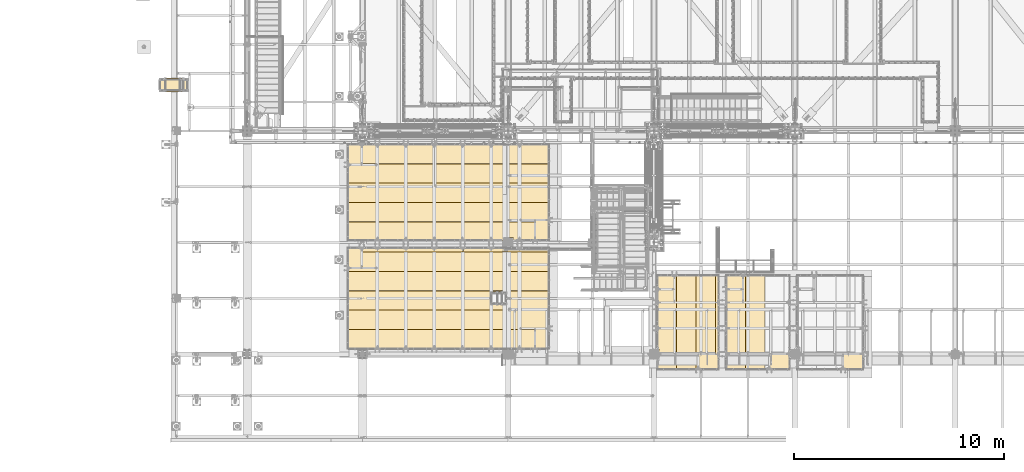
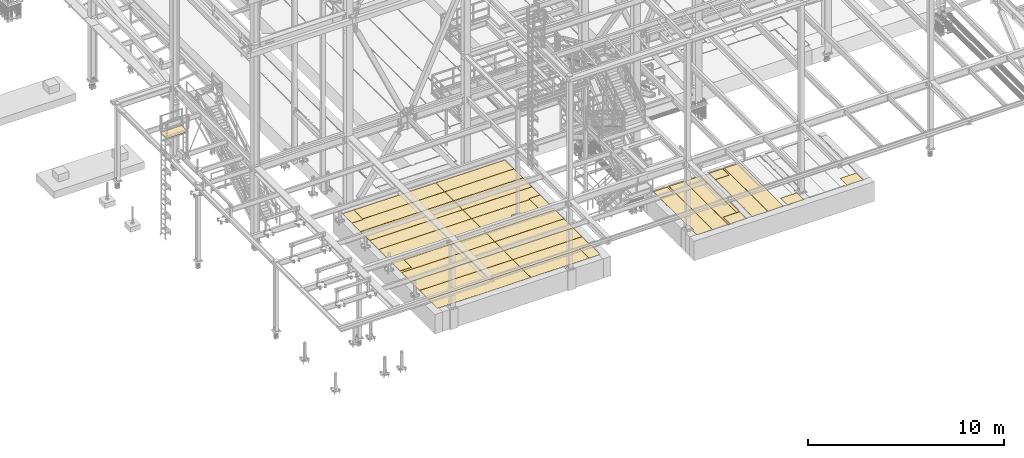
# One storey, part 3837 of 3843: 38 coverings.
"""IFC2X3 building model written with IfcOpenShell, lengths in millimetres."""

from ifc_helpers import new_model, si_unit, frame, origin_with_axes, place, context, subcontext, project, spatial, faceted_brep, material, element, save


model = new_model("IFC2X3")

# Units and contexts
model_context = context("Model", 3, precision=1e-05, world=origin_with_axes())
body_context = subcontext(model_context, "Body", "Model", "MODEL_VIEW")
ifc_project = project(units=[si_unit("LENGTHUNIT", "METRE", prefix="MILLI"), si_unit("AREAUNIT", "SQUARE_METRE"), si_unit("VOLUMEUNIT", "CUBIC_METRE"), si_unit("MASSUNIT", "GRAM", prefix="KILO"), si_unit("TIMEUNIT", "SECOND"), si_unit("PLANEANGLEUNIT", "RADIAN"), si_unit("SOLIDANGLEUNIT", "STERADIAN"), si_unit("THERMODYNAMICTEMPERATUREUNIT", "DEGREE_CELSIUS"), si_unit("LUMINOUSINTENSITYUNIT", "LUMEN")], contexts=[model_context])

# Site, building, storey
site_placement = place(None, origin_with_axes())
site = spatial("IfcSite", under=ifc_project, at=site_placement, CompositionType="ELEMENT")
building_placement = place(site_placement, origin_with_axes())
building = spatial("IfcBuilding", under=site, at=building_placement, Name="Undefined", CompositionType="ELEMENT")
storey_placement = place(building_placement, origin_with_axes())
storey = spatial("IfcBuildingStorey", under=building, at=storey_placement, Name="Undefined", CompositionType="ELEMENT", Elevation=0.0)

# Coverings
ifc_material = material(Name="Undefined/1")
covering_1_placement = place(storey_placement, frame((32457.5233459467, 27476.4499999546, 36765.0760559082), z_axis=(0.0, 1.0, 0.0), x_axis=(1.0, 0.0, 0.0)))
element("IfcCovering", 1, at=covering_1_placement, inside=storey, material=ifc_material, Name="SurfaceTreatment", PredefinedType="NOTDEFINED", context=body_context, shape_type="Brep", body=[
    faceted_brep([(2.88564478978515e-08, -0.5, 647.700000045399), (1247.1656799484, -0.5, 647.699999991924), (1247.1656799484, 0.5, 647.699999991924), (2.88564478978515e-08, 0.5, 647.700000045399), (1247.1656799196, -0.5, -9.38598532229662e-10), (1247.1656799196, 0.5, -9.38598532229662e-10), (0.0, -0.5, 0.0), (0.0, 0.5, 0.0)], [[[0, 1, 2, 3]], [[1, 4, 5, 2]], [[4, 6, 7, 5]], [[6, 0, 3, 7]], [[5, 7, 3, 2]], [[6, 4, 1, 0]]]),
])
for number, where, z_axis, x_axis, name in (
    (2, (59359.7998124687, 18084.8000089393, 30479.2065), (0.0, 1.0, 0.0), (1.0, 0.0, 0.0), "SurfaceTreatment"),
    (3, (56089.5498483771, 18084.8000089393, 30479.2065), (0.0, 1.0, 0.0), (1.0, 0.0, 0.0), "SurfaceTreatment"),
):
    element("IfcCovering", number, at=place(storey_placement, frame(where, z_axis=z_axis, x_axis=x_axis)), inside=storey, material=ifc_material, Name=name, PredefinedType="NOTDEFINED", context=body_context, shape_type="Brep", body=[
        faceted_brep([(-1.84064265340567e-06, -0.793499999999767, 657.224795748214), (809.625124790451, -0.793499999999767, 657.224750979309), (809.625124790451, 0.793499999999767, 657.224750979309), (-1.84064265340567e-06, 0.793499999999767, 657.224795748214), (809.625131159271, -0.793499999999767, -1.3606040738523e-09), (809.625131159271, 0.793499999999767, -1.3606040738523e-09), (-1.45519152283669e-11, -0.793499999999767, 0.0), (-1.45519152283669e-11, 0.793499999999767, 0.0)], [[[0, 1, 2, 3]], [[1, 4, 5, 2]], [[4, 6, 7, 5]], [[6, 0, 3, 7]], [[5, 7, 3, 2]], [[6, 4, 1, 0]]]),
    ])
covering_2_placement = place(storey_placement, frame((41367.075, 20412.0736968403, 30479.2065), z_axis=(0.0, 1.0, 0.0), x_axis=(1.0, 0.0, 0.0)))
element("IfcCovering", 4, at=covering_2_placement, inside=storey, material=ifc_material, Name="SurfaceTreatment", PredefinedType="NOTDEFINED", context=body_context, shape_type="Brep", body=[
    faceted_brep([(0.0, -0.793499999999767, 879.476196497068), (5486.39990234375, -0.793499999999767, 879.476196497068), (5486.39990234375, 0.793499999999767, 879.476196497068), (0.0, 0.793499999999767, 879.476196497068), (5486.39990234375, -0.793499999999767, 0.0), (5486.39990234375, 0.793499999999767, 0.0), (-1.45519152283669e-11, -0.793499999999767, 0.0), (-1.45519152283669e-11, 0.793499999999767, 0.0)], [[[0, 1, 2, 3]], [[1, 4, 5, 2]], [[4, 6, 7, 5]], [[6, 0, 3, 7]], [[5, 7, 3, 2]], [[6, 4, 1, 0]]]),
])
for number, where, z_axis, x_axis, name in (
    (5, (58042.1750028718, 14277.9750716518, 30479.2065), (0.0, 1.0, 0.0), (1.0, 0.0, 0.0), "SurfaceTreatment"),
    (6, (61420.3749756004, 14277.9750719499, 30479.2065), (0.0, 1.0, 0.0), (1.0, 0.0, 0.0), "SurfaceTreatment"),
    (7, (64931.9249999974, 14277.9751077968, 30479.2065), (0.0, 1.0, 0.0), (1.0, 0.0, 0.0), "SurfaceTreatment"),
):
    element("IfcCovering", number, at=place(storey_placement, frame(where, z_axis=z_axis, x_axis=x_axis)), inside=storey, material=ifc_material, Name=name, PredefinedType="NOTDEFINED", context=body_context, shape_type="Brep", body=[
        faceted_brep([(3.82465441362001e-05, -0.793499999999767, 717.549920835538), (962.025013836021, -0.793499999999767, 717.549869919043), (962.025013836021, 0.793499999999767, 717.549869919043), (3.82465441362001e-05, 0.793499999999767, 717.549920835538), (962.025033763661, -0.793499999999767, -2.58842192124575e-09), (962.025033763661, 0.793499999999767, -2.58842192124575e-09), (-1.45519152283669e-11, -0.793499999999767, 0.0), (-1.45519152283669e-11, 0.793499999999767, 0.0)], [[[0, 1, 2, 3]], [[1, 4, 5, 2]], [[4, 6, 7, 5]], [[6, 0, 3, 7]], [[5, 7, 3, 2]], [[6, 4, 1, 0]]]),
    ])
for number, where, z_axis, x_axis, name in (
    (8, (42024.2999786377, 24012.525, 30479.2065), (-1.0, 0.0, 0.0), (0.0, 1.0, 0.0), "SurfaceTreatment"),
    (9, (50936.525066285, 20412.0737027925, 30479.2065), (-1.0, 0.0, 0.0), (0.0, 1.0, 0.0), "SurfaceTreatment"),
    (10, (42024.2999771804, 19094.4499999116, 30479.2065), (-1.0, 0.0, 0.0), (0.0, 1.0, 0.0), "SurfaceTreatment"),
    (11, (50936.5249755859, 15252.6999815394, 30479.2065), (-1.0, 0.0, 0.0), (0.0, 1.0, 0.0), "SurfaceTreatment"),
):
    element("IfcCovering", number, at=place(storey_placement, frame(where, z_axis=z_axis, x_axis=x_axis)), inside=storey, material=ifc_material, Name=name, PredefinedType="NOTDEFINED", context=body_context, shape_type="Brep", body=[
        faceted_brep([(0.0, -0.793499999999767, 657.224975585938), (962.025048828131, -0.793499999999767, 657.224975585938), (962.025048828131, 0.793499999999767, 657.224975585938), (0.0, 0.793499999999767, 657.224975585938), (962.025033763661, -0.793499999999767, -2.58842192124575e-09), (962.025033763661, 0.793499999999767, -2.58842192124575e-09), (-1.45519152283669e-11, -0.793499999999767, 0.0), (-1.45519152283669e-11, 0.793499999999767, 0.0)], [[[0, 1, 2, 3]], [[1, 4, 5, 2]], [[4, 6, 7, 5]], [[6, 0, 3, 7]], [[5, 7, 3, 2]], [[6, 4, 1, 0]]]),
    ])
covering_3_placement = place(storey_placement, frame((61194.9500488281, 14277.9750708574, 30479.2065), z_axis=(-1.0, 0.0, 0.0), x_axis=(0.0, 1.0, 0.0)))
element("IfcCovering", 12, at=covering_3_placement, inside=storey, material=ifc_material, Name="SurfaceTreatment", PredefinedType="NOTDEFINED", context=body_context, shape_type="Brep", body=[
    faceted_brep([(5.36783772986382e-09, -0.793499999999767, 914.400024414062), (4464.04980469289, -0.793499999999767, 914.400025033865), (4464.04980469289, 0.793499999999767, 914.400025033865), (5.36783772986382e-09, 0.793499999999767, 914.400024414062), (4464.04980468753, -0.793499999999767, 1.42608769237995e-08), (4464.04980468753, 0.793499999999767, 1.42608769237995e-08), (-1.45519152283669e-11, -0.793499999999767, 0.0), (-1.45519152283669e-11, 0.793499999999767, 0.0)], [[[0, 1, 2, 3]], [[1, 4, 5, 2]], [[4, 6, 7, 5]], [[6, 0, 3, 7]], [[5, 7, 3, 2]], [[6, 4, 1, 0]]]),
])
covering_4_placement = place(storey_placement, frame((59359.7998474532, 18078.450000003, 30479.2065), z_axis=(1.0, 0.0, 0.0), x_axis=(0.0, -1.0, 0.0)))
element("IfcCovering", 13, at=covering_4_placement, inside=storey, material=ifc_material, Name="SurfaceTreatment", PredefinedType="NOTDEFINED", context=body_context, shape_type="Brep", body=[
    faceted_brep([(-663.574804554046, -0.793499999999767, 914.400025016796), (3800.47500013346, -0.793499999999767, 914.400024430266), (3800.47500013346, 0.793499999999767, 914.400024430266), (-663.574804554046, 0.793499999999767, 914.400025016796), (3800.47500000001, -0.793499999999767, 1.61962816491723e-08), (3800.47500000001, 0.793499999999767, 1.61962816491723e-08), (-1.45519152283669e-11, -0.793499999999767, 0.0), (-1.45519152283669e-11, 0.793499999999767, 0.0), (3.27607158396859e-05, -0.793499999999767, 815.97517946842), (3.27607158396859e-05, 0.793499999999767, 815.97517946842), (-663.574771926786, -0.793499999999767, 815.975206098316), (-663.574771926786, 0.793499999999767, 815.975206098316)], [[[0, 1, 2, 3]], [[1, 4, 5, 2]], [[4, 6, 7, 5]], [[6, 8, 9, 7]], [[8, 10, 11, 9]], [[10, 0, 3, 11]], [[5, 7, 9, 11, 3, 2]], [[10, 8, 6, 4, 1, 0]]]),
])
covering_5_placement = place(storey_placement, frame((59004.1996849625, 15001.8748353989, 30479.2065), z_axis=(-1.0, 0.0, 0.0), x_axis=(0.0, 1.0, 0.0)))
element("IfcCovering", 14, at=covering_5_placement, inside=storey, material=ifc_material, Name="SurfaceTreatment", PredefinedType="NOTDEFINED", context=body_context, shape_type="Brep", body=[
    faceted_brep([(-2.46302333835047e-05, -0.793499999999767, 152.399899291995), (3740.15012185445, -0.793499999999767, 152.399900893091), (3740.15012185445, 0.793499999999767, 152.399900893091), (-2.46302333835047e-05, 0.793499999999767, 152.399899291995), (3740.15014648466, -0.793499999999767, 9.69885149970651e-09), (3740.15014648466, 0.793499999999767, 9.69885149970651e-09), (-1.45519152283669e-11, -0.793499999999767, 0.0), (-1.45519152283669e-11, 0.793499999999767, 0.0)], [[[0, 1, 2, 3]], [[1, 4, 5, 2]], [[4, 6, 7, 5]], [[6, 0, 3, 7]], [[5, 7, 3, 2]], [[6, 4, 1, 0]]]),
])
covering_6_placement = place(storey_placement, frame((58845.4498946794, 18742.0249124911, 30479.2065000002), z_axis=(0.0, -1.0, 0.0), x_axis=(-1.0, 0.0, 0.0)))
element("IfcCovering", 15, at=covering_6_placement, inside=storey, material=ifc_material, Name="SurfaceTreatment", PredefinedType="NOTDEFINED", context=body_context, shape_type="Brep", body=[
    faceted_brep([(4.7221255954355e-05, -0.793499999999767, 3740.14984131871), (809.625020269006, -0.793499999999767, 3740.14996743444), (809.625020269006, 0.793499999999767, 3740.14996743444), (4.7221255954355e-05, 0.793499999999767, 3740.14984131871), (809.624897506437, -0.793499999999767, 4464.04980468742), (809.624897506437, 0.793499999999767, 4464.04980468742), (914.400024350987, -0.793499999999767, 4464.04980468712), (914.400024350987, 0.793499999999767, 4464.04980468712), (914.400025019604, -0.793499999999767, -3.92901711165905e-10), (914.400025019604, 0.793499999999767, -3.92901711165905e-10), (-1.45519152283669e-11, -0.793499999999767, 0.0), (-1.45519152283669e-11, 0.793499999999767, 0.0)], [[[0, 1, 2, 3]], [[1, 4, 5, 2]], [[4, 6, 7, 5]], [[6, 8, 9, 7]], [[8, 10, 11, 9]], [[10, 0, 3, 11]], [[5, 7, 9, 11, 3, 2]], [[10, 8, 6, 4, 1, 0]]]),
])
covering_7_placement = place(storey_placement, frame((57924.7000488281, 14277.9750708574, 30479.2065), z_axis=(-1.0, 0.0, 0.0), x_axis=(0.0, 1.0, 0.0)))
element("IfcCovering", 16, at=covering_7_placement, inside=storey, material=ifc_material, Name="SurfaceTreatment", PredefinedType="NOTDEFINED", context=body_context, shape_type="Brep", body=[
    faceted_brep([(5.36783772986382e-09, -0.793499999999767, 914.400024414062), (4464.04980469289, -0.793499999999767, 914.400025033865), (4464.04980469289, 0.793499999999767, 914.400025033865), (5.36783772986382e-09, 0.793499999999767, 914.400024414062), (4464.04980468753, -0.793499999999767, 1.42608769237995e-08), (4464.04980468753, 0.793499999999767, 1.42608769237995e-08), (-1.45519152283669e-11, -0.793499999999767, 0.0), (-1.45519152283669e-11, 0.793499999999767, 0.0)], [[[0, 1, 2, 3]], [[1, 4, 5, 2]], [[4, 6, 7, 5]], [[6, 0, 3, 7]], [[5, 7, 3, 2]], [[6, 4, 1, 0]]]),
])
covering_8_placement = place(storey_placement, frame((56089.5498474532, 18078.450000003, 30479.2065), z_axis=(1.0, 0.0, 0.0), x_axis=(0.0, -1.0, 0.0)))
element("IfcCovering", 17, at=covering_8_placement, inside=storey, material=ifc_material, Name="SurfaceTreatment", PredefinedType="NOTDEFINED", context=body_context, shape_type="Brep", body=[
    faceted_brep([(-663.574804554046, -0.793499999999767, 914.400025016796), (3800.47500013346, -0.793499999999767, 914.400024430266), (3800.47500013346, 0.793499999999767, 914.400024430266), (-663.574804554046, 0.793499999999767, 914.400025016796), (3800.47500000001, -0.793499999999767, 1.61962816491723e-08), (3800.47500000001, 0.793499999999767, 1.61962816491723e-08), (3321.04998346353, -0.793499999999767, 1.41662894748151e-08), (3321.04998346353, 0.793499999999767, 1.41662894748151e-08), (3321.05000331433, -0.793499999999767, 82.5500147743296), (3321.05000331433, 0.793499999999767, 82.5500147743296), (2838.45000331432, -0.793499999999767, 82.5500341415318), (2838.45000331432, 0.793499999999767, 82.5500341415318), (2838.44998346422, -0.793499999999767, 1.20926415547729e-08), (2838.44998346422, 0.793499999999767, 1.20926415547729e-08), (-1.45519152283669e-11, -0.793499999999767, 0.0), (-1.45519152283669e-11, 0.793499999999767, 0.0), (3.27607158396859e-05, -0.793499999999767, 815.97517946842), (3.27607158396859e-05, 0.793499999999767, 815.97517946842), (-663.574771926786, -0.793499999999767, 815.975206098316), (-663.574771926786, 0.793499999999767, 815.975206098316)], [[[0, 1, 2, 3]], [[1, 4, 5, 2]], [[4, 6, 7, 5]], [[6, 8, 9, 7]], [[8, 10, 11, 9]], [[10, 12, 13, 11]], [[12, 14, 15, 13]], [[14, 16, 17, 15]], [[16, 18, 19, 17]], [[18, 0, 3, 19]], [[5, 7, 9, 11, 13, 15, 17, 19, 3, 2]], [[18, 16, 14, 12, 10, 8, 6, 4, 1, 0]]]),
])
covering_9_placement = place(storey_placement, frame((50272.9501394633, 20412.0736966013, 30479.2065), z_axis=(-1.0, 0.0, 0.0), x_axis=(0.0, 1.0, 0.0)))
element("IfcCovering", 18, at=covering_9_placement, inside=storey, material=ifc_material, Name="SurfaceTreatment", PredefinedType="NOTDEFINED", context=body_context, shape_type="Brep", body=[
    faceted_brep([(-0.000126025552162901, -0.793499999999767, 1035.0501394663), (136.524871467467, -0.793499999999767, 1035.05015612178), (136.524871467467, 0.793499999999767, 1035.05015612178), (-0.000126025552162901, 0.793499999999767, 1035.0501394663), (136.524812576543, -0.793499999999767, 1517.65015612185), (136.524812576543, 0.793499999999767, 1517.65015612185), (-0.000185048396815546, -0.793499999999767, 1517.65013946657), (-0.000185048396815546, 0.793499999999767, 1517.65013946657), (-0.000415403483202681, -0.793499999999767, 3406.77514648469), (-0.000415403483202681, 0.793499999999767, 3406.77514648469), (879.475787049189, -0.793499999999767, 3406.77514648311), (879.475787049189, 0.793499999999767, 3406.77514648311), (879.476202452668, -0.793499999999767, -1.60071067512035e-09), (879.476202452668, 0.793499999999767, -1.60071067512035e-09), (-1.45519152283669e-11, -0.793499999999767, 0.0), (-1.45519152283669e-11, 0.793499999999767, 0.0)], [[[0, 1, 2, 3]], [[1, 4, 5, 2]], [[4, 6, 7, 5]], [[6, 8, 9, 7]], [[8, 10, 11, 9]], [[10, 12, 13, 11]], [[12, 14, 15, 13]], [[14, 0, 3, 15]], [[5, 7, 9, 11, 13, 15, 3, 2]], [[14, 12, 10, 8, 6, 4, 1, 0]]]),
])
covering_10_placement = place(storey_placement, frame((50873.0081665039, 21380.4512788322, 30479.2065), z_axis=(0.0, 1.0, 0.0), x_axis=(1.0, 0.0, 0.0)))
element("IfcCovering", 19, at=covering_10_placement, inside=storey, material=ifc_material, Name="SurfaceTreatment", PredefinedType="NOTDEFINED", context=body_context, shape_type="Brep", body=[
    faceted_brep([(-4006.83326416015, -0.793499999999767, -82.5513764018724), (-4006.83326416015, -0.793499999999767, 831.84864801219), (-4006.83326416015, 0.793499999999767, 831.84864801219), (-4006.83326416015, 0.793499999999767, -82.5513764018724), (63.5168334960981, -0.793499999999767, 831.84864801219), (63.5168334960981, 0.793499999999767, 831.84864801219), (63.5168334960981, -0.793499999999767, 0.0), (63.5168334960981, 0.793499999999767, 0.0), (-600.058166503906, -0.793499999999767, 0.0), (-600.058166503906, 0.793499999999767, 0.0), (-600.058166503906, -0.793499999999767, -82.5513764018724), (-600.058166503906, 0.793499999999767, -82.5513764018724)], [[[0, 1, 2, 3]], [[1, 4, 5, 2]], [[4, 6, 7, 5]], [[6, 8, 9, 7]], [[8, 10, 11, 9]], [[10, 0, 3, 11]], [[5, 7, 9, 11, 3, 2]], [[10, 8, 6, 4, 1, 0]]]),
])
covering_11_placement = place(storey_placement, frame((41367.075, 21297.8998964757, 30479.2065), z_axis=(0.0, 1.0, 0.0), x_axis=(1.0, 0.0, 0.0)))
element("IfcCovering", 20, at=covering_11_placement, inside=storey, material=ifc_material, Name="SurfaceTreatment", PredefinedType="NOTDEFINED", context=body_context, shape_type="Brep", body=[
    faceted_brep([(5.36783772986382e-09, -0.793499999999767, 914.400024414062), (5486.39990234375, -0.793499999999767, 914.400024414062), (5486.39990234375, 0.793499999999767, 914.400024414062), (5.36783772986382e-09, 0.793499999999767, 914.400024414062), (5486.39990234375, -0.793499999999767, 0.0), (5486.39990234375, 0.793499999999767, 0.0), (-1.45519152283669e-11, -0.793499999999767, 0.0), (-1.45519152283669e-11, 0.793499999999767, 0.0)], [[[0, 1, 2, 3]], [[1, 4, 5, 2]], [[4, 6, 7, 5]], [[6, 0, 3, 7]], [[5, 7, 3, 2]], [[6, 4, 1, 0]]]),
])
covering_12_placement = place(storey_placement, frame((46866.1749023438, 22218.6499268443, 30479.2065), z_axis=(0.0, 1.0, 0.0), x_axis=(1.0, 0.0, 0.0)))
element("IfcCovering", 21, at=covering_12_placement, inside=storey, material=ifc_material, Name="SurfaceTreatment", PredefinedType="NOTDEFINED", context=body_context, shape_type="Brep", body=[
    faceted_brep([(5.36783772986382e-09, -0.793499999999767, 914.400024414062), (4070.35009765625, -0.793499999999767, 914.400024414062), (4070.35009765625, 0.793499999999767, 914.400024414062), (5.36783772986382e-09, 0.793499999999767, 914.400024414062), (4070.35009765625, -0.793499999999767, 0.0), (4070.35009765625, 0.793499999999767, 0.0), (-1.45519152283669e-11, -0.793499999999767, 0.0), (-1.45519152283669e-11, 0.793499999999767, 0.0)], [[[0, 1, 2, 3]], [[1, 4, 5, 2]], [[4, 6, 7, 5]], [[6, 0, 3, 7]], [[5, 7, 3, 2]], [[6, 4, 1, 0]]]),
])
covering_13_placement = place(storey_placement, frame((41367.075, 22218.6499208897, 30479.2065), z_axis=(0.0, 1.0, 0.0), x_axis=(1.0, 0.0, 0.0)))
element("IfcCovering", 22, at=covering_13_placement, inside=storey, material=ifc_material, Name="SurfaceTreatment", PredefinedType="NOTDEFINED", context=body_context, shape_type="Brep", body=[
    faceted_brep([(5.36783772986382e-09, -0.793499999999767, 914.400024414062), (5486.39990234375, -0.793499999999767, 914.400024414062), (5486.39990234375, 0.793499999999767, 914.400024414062), (5.36783772986382e-09, 0.793499999999767, 914.400024414062), (5486.39990234375, -0.793499999999767, 0.0), (5486.39990234375, 0.793499999999767, 0.0), (-1.45519152283669e-11, -0.793499999999767, 0.0), (-1.45519152283669e-11, 0.793499999999767, 0.0)], [[[0, 1, 2, 3]], [[1, 4, 5, 2]], [[4, 6, 7, 5]], [[6, 0, 3, 7]], [[5, 7, 3, 2]], [[6, 4, 1, 0]]]),
])
covering_14_placement = place(storey_placement, frame((46866.1749023438, 23139.3999512584, 30479.2065), z_axis=(0.0, 1.0, 0.0), x_axis=(1.0, 0.0, 0.0)))
element("IfcCovering", 23, at=covering_14_placement, inside=storey, material=ifc_material, Name="SurfaceTreatment", PredefinedType="NOTDEFINED", context=body_context, shape_type="Brep", body=[
    faceted_brep([(5.36783772986382e-09, -0.793499999999767, 914.400024414062), (4070.35009765625, -0.793499999999767, 914.400024414062), (4070.35009765625, 0.793499999999767, 914.400024414062), (5.36783772986382e-09, 0.793499999999767, 914.400024414062), (4070.35009765625, -0.793499999999767, 0.0), (4070.35009765625, 0.793499999999767, 0.0), (-1.45519152283669e-11, -0.793499999999767, 0.0), (-1.45519152283669e-11, 0.793499999999767, 0.0)], [[[0, 1, 2, 3]], [[1, 4, 5, 2]], [[4, 6, 7, 5]], [[6, 0, 3, 7]], [[5, 7, 3, 2]], [[6, 4, 1, 0]]]),
])
covering_15_placement = place(storey_placement, frame((41367.075, 23139.3999453038, 30479.2065), z_axis=(0.0, 1.0, 0.0), x_axis=(1.0, 0.0, 0.0)))
element("IfcCovering", 24, at=covering_15_placement, inside=storey, material=ifc_material, Name="SurfaceTreatment", PredefinedType="NOTDEFINED", context=body_context, shape_type="Brep", body=[
    faceted_brep([(0.0, -0.793499999999767, 866.775054696227), (663.575000000004, -0.793499999999767, 866.775054696227), (663.575000000004, 0.793499999999767, 866.775054696227), (0.0, 0.793499999999767, 866.775054696227), (663.575000000004, -0.793499999999767, 914.400024414062), (663.575000000004, 0.793499999999767, 914.400024414062), (5486.39990234375, -0.793499999999767, 914.400024414062), (5486.39990234375, 0.793499999999767, 914.400024414062), (5486.39990234375, -0.793499999999767, 0.0), (5486.39990234375, 0.793499999999767, 0.0), (-1.45519152283669e-11, -0.793499999999767, 0.0), (-1.45519152283669e-11, 0.793499999999767, 0.0)], [[[0, 1, 2, 3]], [[1, 4, 5, 2]], [[4, 6, 7, 5]], [[6, 8, 9, 7]], [[8, 10, 11, 9]], [[10, 0, 3, 11]], [[5, 7, 9, 11, 3, 2]], [[10, 8, 6, 4, 1, 0]]]),
])
covering_16_placement = place(storey_placement, frame((46859.8249043368, 19856.4501025318, 30479.2065), z_axis=(0.0, 1.0, 0.0), x_axis=(1.0, 0.0, 0.0)))
element("IfcCovering", 25, at=covering_16_placement, inside=storey, material=ifc_material, Name="SurfaceTreatment", PredefinedType="NOTDEFINED", context=body_context, shape_type="Brep", body=[
    faceted_brep([(-2.08841811399907e-07, -0.793499999999767, 200.024899087206), (4076.7000974474, -0.793499999999767, 200.024897402225), (4076.7000974474, 0.793499999999767, 200.024897402225), (-2.08841811399907e-07, 0.793499999999767, 200.024899087206), (4076.70009765688, -0.793499999999767, 1.05173967313021e-08), (4076.70009765688, 0.793499999999767, 1.05173967313021e-08), (-1.45519152283669e-11, -0.793499999999767, 0.0), (-1.45519152283669e-11, 0.793499999999767, 0.0)], [[[0, 1, 2, 3]], [[1, 4, 5, 2]], [[4, 6, 7, 5]], [[6, 0, 3, 7]], [[5, 7, 3, 2]], [[6, 4, 1, 0]]]),
])
covering_17_placement = place(storey_placement, frame((42030.65, 19856.4501029269, 30479.2065), z_axis=(0.0, 1.0, 0.0), x_axis=(1.0, 0.0, 0.0)))
element("IfcCovering", 26, at=covering_17_placement, inside=storey, material=ifc_material, Name="SurfaceTreatment", PredefinedType="NOTDEFINED", context=body_context, shape_type="Brep", body=[
    faceted_brep([(-2.08841811399907e-07, -0.793499999999767, 200.024899087206), (4822.82470703125, -0.793499999999767, 200.024898692147), (4822.82470703125, 0.793499999999767, 200.024898692147), (-2.08841811399907e-07, 0.793499999999767, 200.024899087206), (4822.82470703125, -0.793499999999767, 0.0), (4822.82470703125, 0.793499999999767, 0.0), (-1.45519152283669e-11, -0.793499999999767, 0.0), (-1.45519152283669e-11, 0.793499999999767, 0.0)], [[[0, 1, 2, 3]], [[1, 4, 5, 2]], [[4, 6, 7, 5]], [[6, 0, 3, 7]], [[5, 7, 3, 2]], [[6, 4, 1, 0]]]),
])
covering_18_placement = place(storey_placement, frame((46859.8249035329, 18935.7000785128, 30479.2065), z_axis=(0.0, 1.0, 0.0), x_axis=(1.0, 0.0, 0.0)))
element("IfcCovering", 27, at=covering_18_placement, inside=storey, material=ifc_material, Name="SurfaceTreatment", PredefinedType="NOTDEFINED", context=body_context, shape_type="Brep", body=[
    faceted_brep([(5.36783772986382e-09, -0.793499999999767, 914.400024414062), (4076.7000976556, -0.793499999999767, 914.400022629714), (4076.7000976556, 0.793499999999767, 914.400022629714), (5.36783772986382e-09, 0.793499999999767, 914.400024414062), (4076.70009765688, -0.793499999999767, 1.05173967313021e-08), (4076.70009765688, 0.793499999999767, 1.05173967313021e-08), (-1.45519152283669e-11, -0.793499999999767, 0.0), (-1.45519152283669e-11, 0.793499999999767, 0.0)], [[[0, 1, 2, 3]], [[1, 4, 5, 2]], [[4, 6, 7, 5]], [[6, 0, 3, 7]], [[5, 7, 3, 2]], [[6, 4, 1, 0]]]),
])
covering_19_placement = place(storey_placement, frame((41367.0750015867, 18935.7000785128, 30479.2065), z_axis=(0.0, 1.0, 0.0), x_axis=(1.0, 0.0, 0.0)))
element("IfcCovering", 28, at=covering_19_placement, inside=storey, material=ifc_material, Name="SurfaceTreatment", PredefinedType="NOTDEFINED", context=body_context, shape_type="Brep", body=[
    faceted_brep([(-2.46302333835047e-05, -0.793499999999767, 152.399899291995), (663.5749984133, -0.793499999999767, 152.399921487184), (663.5749984133, 0.793499999999767, 152.399921487184), (-2.46302333835047e-05, 0.793499999999767, 152.399899291995), (663.575000000004, -0.793499999999767, 914.400024414062), (663.575000000004, 0.793499999999767, 914.400024414062), (5486.39990234375, -0.793499999999767, 914.400024414062), (5486.39990234375, 0.793499999999767, 914.400024414062), (5486.39990234375, -0.793499999999767, 0.0), (5486.39990234375, 0.793499999999767, 0.0), (-1.45519152283669e-11, -0.793499999999767, 0.0), (-1.45519152283669e-11, 0.793499999999767, 0.0)], [[[0, 1, 2, 3]], [[1, 4, 5, 2]], [[4, 6, 7, 5]], [[6, 8, 9, 7]], [[8, 10, 11, 9]], [[10, 0, 3, 11]], [[5, 7, 9, 11, 3, 2]], [[10, 8, 6, 4, 1, 0]]]),
])
covering_20_placement = place(storey_placement, frame((46859.8249031293, 18014.9500542698, 30479.2065), z_axis=(0.0, 1.0, 0.0), x_axis=(1.0, 0.0, 0.0)))
element("IfcCovering", 29, at=covering_20_placement, inside=storey, material=ifc_material, Name="SurfaceTreatment", PredefinedType="NOTDEFINED", context=body_context, shape_type="Brep", body=[
    faceted_brep([(5.36783772986382e-09, -0.793499999999767, 914.400024414062), (4076.7000976556, -0.793499999999767, 914.400022629714), (4076.7000976556, 0.793499999999767, 914.400022629714), (5.36783772986382e-09, 0.793499999999767, 914.400024414062), (4076.70009765688, -0.793499999999767, 1.05173967313021e-08), (4076.70009765688, 0.793499999999767, 1.05173967313021e-08), (-1.45519152283669e-11, -0.793499999999767, 0.0), (-1.45519152283669e-11, 0.793499999999767, 0.0)], [[[0, 1, 2, 3]], [[1, 4, 5, 2]], [[4, 6, 7, 5]], [[6, 0, 3, 7]], [[5, 7, 3, 2]], [[6, 4, 1, 0]]]),
])
covering_21_placement = place(storey_placement, frame((41367.0750011831, 18014.9500542698, 30479.2065), z_axis=(0.0, 1.0, 0.0), x_axis=(1.0, 0.0, 0.0)))
element("IfcCovering", 30, at=covering_21_placement, inside=storey, material=ifc_material, Name="SurfaceTreatment", PredefinedType="NOTDEFINED", context=body_context, shape_type="Brep", body=[
    faceted_brep([(5.36783772986382e-09, -0.793499999999767, 914.400024414062), (5486.39990234375, -0.793499999999767, 914.400024414062), (5486.39990234375, 0.793499999999767, 914.400024414062), (5.36783772986382e-09, 0.793499999999767, 914.400024414062), (5486.39990234375, -0.793499999999767, 0.0), (5486.39990234375, 0.793499999999767, 0.0), (-1.45519152283669e-11, -0.793499999999767, 0.0), (-1.45519152283669e-11, 0.793499999999767, 0.0)], [[[0, 1, 2, 3]], [[1, 4, 5, 2]], [[4, 6, 7, 5]], [[6, 0, 3, 7]], [[5, 7, 3, 2]], [[6, 4, 1, 0]]]),
])
covering_22_placement = place(storey_placement, frame((46859.8249027257, 17094.2000300267, 30479.2065), z_axis=(0.0, 1.0, 0.0), x_axis=(1.0, 0.0, 0.0)))
element("IfcCovering", 31, at=covering_22_placement, inside=storey, material=ifc_material, Name="SurfaceTreatment", PredefinedType="NOTDEFINED", context=body_context, shape_type="Brep", body=[
    faceted_brep([(5.36783772986382e-09, -0.793499999999767, 914.400024414062), (4076.7000976556, -0.793499999999767, 914.400022629714), (4076.7000976556, 0.793499999999767, 914.400022629714), (5.36783772986382e-09, 0.793499999999767, 914.400024414062), (4076.70009765688, -0.793499999999767, 1.05173967313021e-08), (4076.70009765688, 0.793499999999767, 1.05173967313021e-08), (-1.45519152283669e-11, -0.793499999999767, 0.0), (-1.45519152283669e-11, 0.793499999999767, 0.0)], [[[0, 1, 2, 3]], [[1, 4, 5, 2]], [[4, 6, 7, 5]], [[6, 0, 3, 7]], [[5, 7, 3, 2]], [[6, 4, 1, 0]]]),
])
covering_23_placement = place(storey_placement, frame((41367.0750007794, 17094.2000300267, 30479.2065), z_axis=(0.0, 1.0, 0.0), x_axis=(1.0, 0.0, 0.0)))
element("IfcCovering", 32, at=covering_23_placement, inside=storey, material=ifc_material, Name="SurfaceTreatment", PredefinedType="NOTDEFINED", context=body_context, shape_type="Brep", body=[
    faceted_brep([(5.36783772986382e-09, -0.793499999999767, 914.400024414062), (5486.39990234375, -0.793499999999767, 914.400024414062), (5486.39990234375, 0.793499999999767, 914.400024414062), (5.36783772986382e-09, 0.793499999999767, 914.400024414062), (5486.39990234375, -0.793499999999767, 0.0), (5486.39990234375, 0.793499999999767, 0.0), (-1.45519152283669e-11, -0.793499999999767, 0.0), (-1.45519152283669e-11, 0.793499999999767, 0.0)], [[[0, 1, 2, 3]], [[1, 4, 5, 2]], [[4, 6, 7, 5]], [[6, 0, 3, 7]], [[5, 7, 3, 2]], [[6, 4, 1, 0]]]),
])
covering_24_placement = place(storey_placement, frame((50936.5249999776, 16221.075, 30479.2065), z_axis=(-1.0, 0.0, 0.0), x_axis=(0.0, 1.0, 0.0)))
element("IfcCovering", 33, at=covering_24_placement, inside=storey, material=ifc_material, Name="SurfaceTreatment", PredefinedType="NOTDEFINED", context=body_context, shape_type="Brep", body=[
    faceted_brep([(-47.6249942163795, -0.793499999999767, 4076.7000976556), (866.775030197683, -0.793499999999767, 4076.70009765625), (866.775030197683, 0.793499999999767, 4076.70009765625), (-47.6249942163795, 0.793499999999767, 4076.7000976556), (866.775028413338, -0.793499999999767, 0.0), (866.775028413338, 0.793499999999767, 0.0), (-1.45519152283669e-11, -0.793499999999767, 0.0), (-1.45519152283669e-11, 0.793499999999767, 0.0), (0.0, -0.793499999999767, 663.574999977638), (0.0, 0.793499999999767, 663.574999977638), (-47.6249942163795, -0.793499999999767, 663.574999977638), (-47.6249942163795, 0.793499999999767, 663.574999977638)], [[[0, 1, 2, 3]], [[1, 4, 5, 2]], [[4, 6, 7, 5]], [[6, 8, 9, 7]], [[8, 10, 11, 9]], [[10, 0, 3, 11]], [[5, 7, 9, 11, 3, 2]], [[10, 8, 6, 4, 1, 0]]]),
])
covering_25_placement = place(storey_placement, frame((41367.0750003758, 16173.4500057836, 30479.2065), z_axis=(0.0, 1.0, 0.0), x_axis=(1.0, 0.0, 0.0)))
element("IfcCovering", 34, at=covering_25_placement, inside=storey, material=ifc_material, Name="SurfaceTreatment", PredefinedType="NOTDEFINED", context=body_context, shape_type="Brep", body=[
    faceted_brep([(5.36783772986382e-09, -0.793499999999767, 914.400024414062), (5486.39990234375, -0.793499999999767, 914.400024414062), (5486.39990234375, 0.793499999999767, 914.400024414062), (5.36783772986382e-09, 0.793499999999767, 914.400024414062), (5486.39990234375, -0.793499999999767, 0.0), (5486.39990234375, 0.793499999999767, 0.0), (-1.45519152283669e-11, -0.793499999999767, 0.0), (-1.45519152283669e-11, 0.793499999999767, 0.0)], [[[0, 1, 2, 3]], [[1, 4, 5, 2]], [[4, 6, 7, 5]], [[6, 0, 3, 7]], [[5, 7, 3, 2]], [[6, 4, 1, 0]]]),
])
covering_26_placement = place(storey_placement, frame((46866.1749023438, 24060.1499756725, 30479.2065), z_axis=(0.0, 1.0, 0.0), x_axis=(1.0, 0.0, 0.0)))
element("IfcCovering", 35, at=covering_26_placement, inside=storey, material=ifc_material, Name="SurfaceTreatment", PredefinedType="NOTDEFINED", context=body_context, shape_type="Brep", body=[
    faceted_brep([(5.36783772986382e-09, -0.793499999999767, 914.400024414062), (4070.35009765625, -0.793499999999767, 914.400024414062), (4070.35009765625, 0.793499999999767, 914.400024414062), (5.36783772986382e-09, 0.793499999999767, 914.400024414062), (4070.35009765625, -0.793499999999767, 0.0), (4070.35009765625, 0.793499999999767, 0.0), (-1.45519152283669e-11, -0.793499999999767, 0.0), (-1.45519152283669e-11, 0.793499999999767, 0.0)], [[[0, 1, 2, 3]], [[1, 4, 5, 2]], [[4, 6, 7, 5]], [[6, 0, 3, 7]], [[5, 7, 3, 2]], [[6, 4, 1, 0]]]),
])
covering_27_placement = place(storey_placement, frame((42030.6499969482, 24060.1499697178, 30479.2065), z_axis=(0.0, 1.0, 0.0), x_axis=(1.0, 0.0, 0.0)))
element("IfcCovering", 36, at=covering_27_placement, inside=storey, material=ifc_material, Name="SurfaceTreatment", PredefinedType="NOTDEFINED", context=body_context, shape_type="Brep", body=[
    faceted_brep([(5.36783772986382e-09, -0.793499999999767, 914.400024414062), (4822.82470703125, -0.793499999999767, 914.400024414062), (4822.82470703125, 0.793499999999767, 914.400024414062), (5.36783772986382e-09, 0.793499999999767, 914.400024414062), (4822.82470703125, -0.793499999999767, 0.0), (4822.82470703125, 0.793499999999767, 0.0), (-1.45519152283669e-11, -0.793499999999767, 0.0), (-1.45519152283669e-11, 0.793499999999767, 0.0)], [[[0, 1, 2, 3]], [[1, 4, 5, 2]], [[4, 6, 7, 5]], [[6, 0, 3, 7]], [[5, 7, 3, 2]], [[6, 4, 1, 0]]]),
])
covering_28_placement = place(storey_placement, frame((46859.8249028577, 15252.6999815479, 30479.2065), z_axis=(0.0, 1.0, 0.0), x_axis=(1.0, 0.0, 0.0)))
element("IfcCovering", 37, at=covering_28_placement, inside=storey, material=ifc_material, Name="SurfaceTreatment", PredefinedType="NOTDEFINED", context=body_context, shape_type="Brep", body=[
    faceted_brep([(5.36783772986382e-09, -0.793499999999767, 914.400024414062), (3413.12514649038, -0.793499999999767, 914.400022642667), (3413.12514649038, 0.793499999999767, 914.400022642667), (5.36783772986382e-09, 0.793499999999767, 914.400024414062), (3413.12514648411, -0.793499999999767, 1.27747625811026e-08), (3413.12514648411, 0.793499999999767, 1.27747625811026e-08), (-1.45519152283669e-11, -0.793499999999767, 0.0), (-1.45519152283669e-11, 0.793499999999767, 0.0)], [[[0, 1, 2, 3]], [[1, 4, 5, 2]], [[4, 6, 7, 5]], [[6, 0, 3, 7]], [[5, 7, 3, 2]], [[6, 4, 1, 0]]]),
])
covering_29_placement = place(storey_placement, frame((41367.075, 15252.6999815406, 30479.2065), z_axis=(0.0, 1.0, 0.0), x_axis=(1.0, 0.0, 0.0)))
element("IfcCovering", 38, at=covering_29_placement, inside=storey, material=ifc_material, Name="SurfaceTreatment", PredefinedType="NOTDEFINED", context=body_context, shape_type="Brep", body=[
    faceted_brep([(5.36783772986382e-09, -0.793499999999767, 914.400024414062), (5486.39990234375, -0.793499999999767, 914.400024414062), (5486.39990234375, 0.793499999999767, 914.400024414062), (5.36783772986382e-09, 0.793499999999767, 914.400024414062), (5486.39990234375, -0.793499999999767, 0.0), (5486.39990234375, 0.793499999999767, 0.0), (-1.45519152283669e-11, -0.793499999999767, 0.0), (-1.45519152283669e-11, 0.793499999999767, 0.0)], [[[0, 1, 2, 3]], [[1, 4, 5, 2]], [[4, 6, 7, 5]], [[6, 0, 3, 7]], [[5, 7, 3, 2]], [[6, 4, 1, 0]]]),
])

save(model, "model.ifc")
